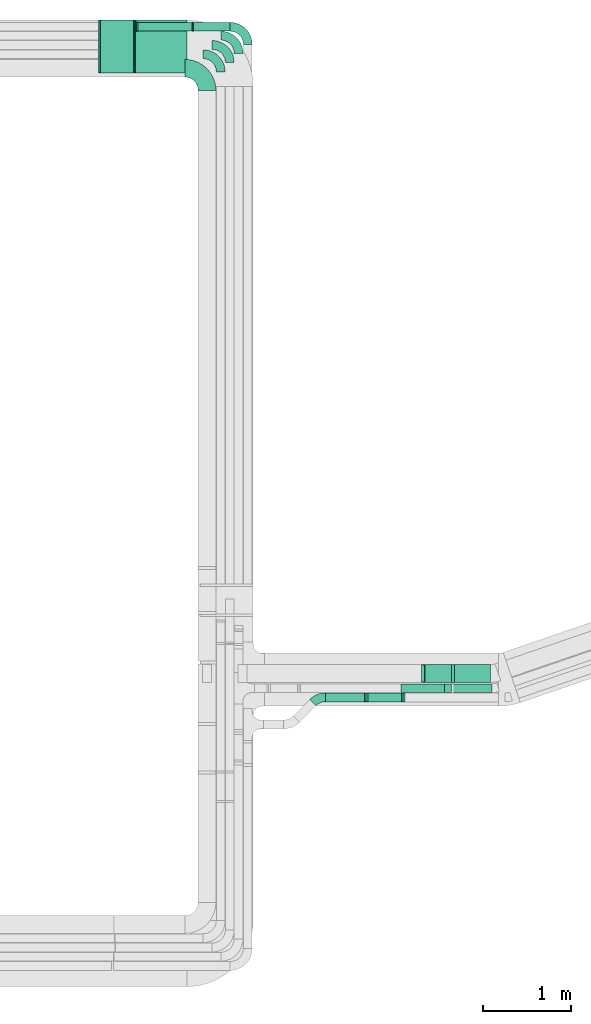
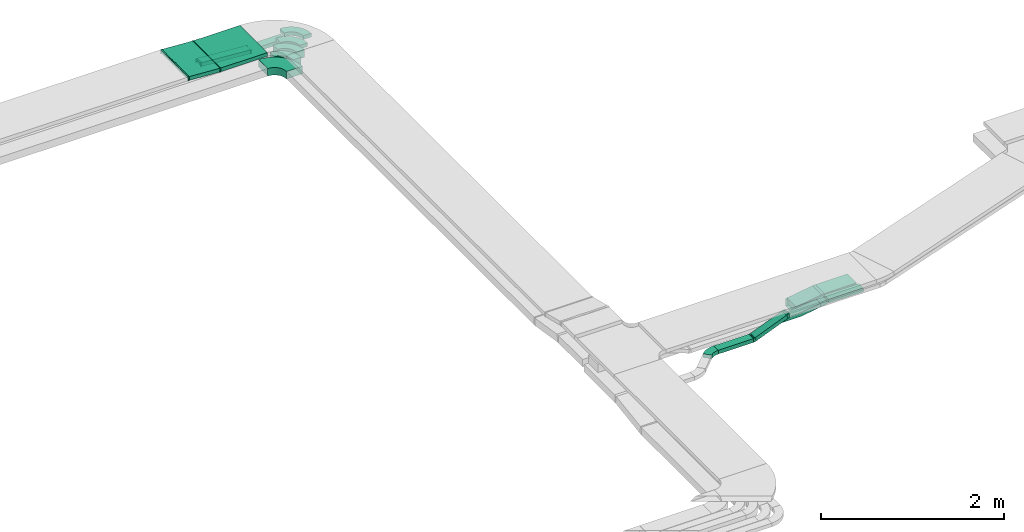
# One storey, part 32 of 38: 15 flow fittings, 10 flow segments.
"""IFC2X3 building model written with IfcOpenShell, lengths in millimetres."""

from ifc_helpers import new_model, entity, si_unit, converted_unit, derived_unit, direction, frame, frame_2d, origin, origin_2d_with_axis, place, context, subcontext, project, spatial, polyline, circle_curve, parameter, trimmed, segment, composite_curve, rectangle, outline, extrude, faceted_brep, source, transform, mapped, material, type_object, type_shapes, element, save


model = new_model("IFC2X3")

# Units and contexts
model_context = context("Model", 3, precision=0.01, world=origin(), true_north=direction((6.12303176911189e-17, 1.0)))
body_context = subcontext(model_context, "Body", "Model", "MODEL_VIEW")
ifc_project = project(units=[si_unit("LENGTHUNIT", "METRE", prefix="MILLI"), si_unit("AREAUNIT", "SQUARE_METRE"), si_unit("VOLUMEUNIT", "CUBIC_METRE"), converted_unit("PLANEANGLEUNIT", "DEGREE", entity("IfcRatioMeasure", 0.0174532925199433), si_unit("PLANEANGLEUNIT", "RADIAN"), dimensions=[0, 0, 0, 0, 0, 0, 0]), si_unit("MASSUNIT", "GRAM", prefix="KILO"), derived_unit("MASSDENSITYUNIT", [(si_unit("MASSUNIT", "GRAM", prefix="KILO"), 1), (si_unit("LENGTHUNIT", "METRE"), -3)]), derived_unit("MOMENTOFINERTIAUNIT", [(si_unit("LENGTHUNIT", "METRE"), 4)]), si_unit("TIMEUNIT", "SECOND"), si_unit("FREQUENCYUNIT", "HERTZ"), si_unit("THERMODYNAMICTEMPERATUREUNIT", "DEGREE_CELSIUS"), derived_unit("THERMALTRANSMITTANCEUNIT", [(si_unit("MASSUNIT", "GRAM", prefix="KILO"), 1), (si_unit("THERMODYNAMICTEMPERATUREUNIT", "KELVIN"), -1), (si_unit("TIMEUNIT", "SECOND"), -3)]), derived_unit("VOLUMETRICFLOWRATEUNIT", [(si_unit("LENGTHUNIT", "METRE"), 3), (si_unit("TIMEUNIT", "SECOND"), -1)]), derived_unit("MASSFLOWRATEUNIT", [(si_unit("MASSUNIT", "GRAM", prefix="KILO"), 1), (si_unit("TIMEUNIT", "SECOND"), -1)]), derived_unit("ROTATIONALFREQUENCYUNIT", [(si_unit("TIMEUNIT", "SECOND"), -1)]), si_unit("ELECTRICCURRENTUNIT", "AMPERE"), si_unit("ELECTRICVOLTAGEUNIT", "VOLT"), si_unit("POWERUNIT", "WATT"), si_unit("FORCEUNIT", "NEWTON", prefix="KILO"), si_unit("ILLUMINANCEUNIT", "LUX"), si_unit("LUMINOUSFLUXUNIT", "LUMEN"), si_unit("LUMINOUSINTENSITYUNIT", "CANDELA"), derived_unit("USERDEFINED", [(si_unit("MASSUNIT", "GRAM", prefix="KILO"), -1), (si_unit("LENGTHUNIT", "METRE"), -2), (si_unit("TIMEUNIT", "SECOND"), 3), (si_unit("LUMINOUSFLUXUNIT", "LUMEN"), 1)]), derived_unit("LINEARVELOCITYUNIT", [(si_unit("LENGTHUNIT", "METRE"), 1), (si_unit("TIMEUNIT", "SECOND"), -1)]), si_unit("PRESSUREUNIT", "PASCAL"), derived_unit("USERDEFINED", [(si_unit("LENGTHUNIT", "METRE"), -2), (si_unit("MASSUNIT", "GRAM", prefix="KILO"), 1), (si_unit("TIMEUNIT", "SECOND"), -2)]), derived_unit("LINEARFORCEUNIT", [(si_unit("MASSUNIT", "GRAM", prefix="KILO"), 1), (si_unit("LENGTHUNIT", "METRE"), 1), (si_unit("TIMEUNIT", "SECOND"), -2), (si_unit("LENGTHUNIT", "METRE"), -1)]), derived_unit("PLANARFORCEUNIT", [(si_unit("MASSUNIT", "GRAM", prefix="KILO"), 1), (si_unit("LENGTHUNIT", "METRE"), 1), (si_unit("TIMEUNIT", "SECOND"), -2), (si_unit("LENGTHUNIT", "METRE"), -2)])], contexts=[model_context])

# Site, building, storey
site_placement = place(None, frame((0.0, -0.00077364408347762, 0.0)))
site = spatial("IfcSite", under=ifc_project, at=site_placement, CompositionType="ELEMENT")
building_placement = place(site_placement, origin())
building = spatial("IfcBuilding", under=site, at=building_placement, CompositionType="ELEMENT")
storey_placement = place(building_placement, frame((0.0, 0.0, 4200.0)))
storey = spatial("IfcBuildingStorey", under=building, at=storey_placement, CompositionType="ELEMENT", Elevation=4200.0)

# Flow segments
cable_carrier_segment_type = type_object("IfcCableCarrierSegmentType", PredefinedType="CABLETRAYSEGMENT")
flow_segment_1_placement = place(storey_placement, frame((60757.9387211652, 15566.1524230659, 2773.40465238002)))
element("IfcFlowSegment", 1, at=flow_segment_1_placement, inside=storey, type_object=cable_carrier_segment_type, context=body_context, shape_type="SweptSolid", body=[
    extrude(rectangle(XDim=585.094690368982, YDim=600.000000000002, at=frame_2d((4.32009983342141e-12, 0.0), x_axis=(1.0, 0.0))), frame((292.547345184487, 300.0, 0.0), z_axis=(0.0, 0.0, 1.0), x_axis=(-1.0, 0.0, 0.0)), (0.0, 0.0, 1.0), 49.9999999999995),
])
flow_segment_2_placement = place(storey_placement, frame((60355.6874307794, 15566.1524230659, 2773.86555364525)))
element("IfcFlowSegment", 2, at=flow_segment_2_placement, inside=storey, type_object=cable_carrier_segment_type, context=body_context, shape_type="SweptSolid", body=[
    extrude(rectangle(XDim=49.9999999999996, YDim=388.064289471167, at=frame_2d((-4.2632564145606e-14, -5.40012479177676e-13), x_axis=(0.0, 1.0))), frame((195.204937503491, 0.0, 36.9237737330479), z_axis=(0.0, 1.0, 0.0), x_axis=(-0.998094861417354, 0.0, 0.0616980357245901)), (0.0, 0.0, 1.0), 600.000000000002),
])
flow_segment_3_placement = place(storey_placement, frame((61417.2080814007, 16039.1762792241, 2500.0)))
element("IfcFlowSegment", 3, at=flow_segment_3_placement, inside=storey, type_object=cable_carrier_segment_type, context=body_context, shape_type="SweptSolid", body=[
    extrude(rectangle(XDim=422.974945905387, YDim=99.9999999999989, at=frame_2d((4.33431068813661e-12, 1.08357767203415e-12), x_axis=(1.0, 0.0))), frame((211.487472952698, 50.0, 0.0), z_axis=(0.0, 0.0, 1.0), x_axis=(-1.0, 0.0, 0.0)), (0.0, 0.0, 1.0), 49.9999999999995),
])
flow_segment_4_placement = place(storey_placement, frame((60781.9444853442, 16039.1762792241, 2500.58430369179)))
element("IfcFlowSegment", 4, at=flow_segment_4_placement, inside=storey, type_object=cable_carrier_segment_type, context=body_context, shape_type="SweptSolid", body=[
    extrude(rectangle(XDim=50.0000000000008, YDim=99.9999999999989, at=frame_2d((0.0, 0.0), x_axis=(0.0, 1.0))), frame((1.83846594978193, 50.0, 70.6053693391281), z_axis=(0.997292368727615, 0.0, -0.0735386379916224), x_axis=(0.0, 1.0, 0.0)), (0.0, 0.0, 1.0), 621.075687126531),
])
flow_segment_5_placement = place(storey_placement, frame((64362.9795024162, 8547.4444137045, 2683.26969738223)))
element("IfcFlowSegment", 5, at=flow_segment_5_placement, inside=storey, type_object=cable_carrier_segment_type, context=body_context, shape_type="SweptSolid", body=[
    extrude(rectangle(XDim=100.000000000001, YDim=438.35134819234, at=frame_2d((4.32009983342141e-12, 0.0), x_axis=(0.0, 1.0))), frame((219.175674182974, 50.0071311780554, 0.0178429227607808), z_axis=(4.88705511740176e-05, -0.000142633733288134, 0.999999988633644), x_axis=(-1.0, 0.0, 4.88705516711381e-05)), (0.0, 0.0, 1.0), 50.0000000000004),
])
flow_segment_6_placement = place(storey_placement, frame((64374.0733170513, 8663.78573364406, 2637.16330868192)))
element("IfcFlowSegment", 6, at=flow_segment_6_placement, inside=storey, type_object=cable_carrier_segment_type, context=body_context, shape_type="SweptSolid", body=[
    extrude(rectangle(XDim=408.398049155987, YDim=200.0, at=origin_2d_with_axis()), frame((204.199024577994, 100.0, 0.0), z_axis=(0.0, 0.0, 1.0), x_axis=(-1.0, 0.0, 0.0)), (0.0, 0.0, 1.0), 99.9999999999989),
])
flow_segment_7_placement = place(storey_placement, frame((64021.5891230622, 8663.78573364406, 2585.29047953296)))
element("IfcFlowSegment", 7, at=flow_segment_7_placement, inside=storey, type_object=cable_carrier_segment_type, context=body_context, shape_type="SweptSolid", body=[
    extrude(rectangle(XDim=99.9999999999992, YDim=200.0, at=origin_2d_with_axis()), frame((7.82172325201104, 100.0, 49.3844170297565), z_axis=(0.987688340595139, 0.0, 0.156434465040222), x_axis=(-0.156434465040222, 0.0, 0.987688340595139)), (0.0, 0.0, 1.0), 322.266039926172),
])
flow_segment_8_placement = place(storey_placement, frame((64258.9077822415, 8547.44797903922, 2669.22010191071)))
element("IfcFlowSegment", 8, at=flow_segment_8_placement, inside=storey, type_object=cable_carrier_segment_type, context=body_context, shape_type="SweptSolid", body=[
    extrude(rectangle(XDim=49.9999999999996, YDim=82.6344223697702, at=frame_2d((0.0, 0.0), x_axis=(0.0, 1.0))), frame((44.7193893792236, 0.0, 31.1556443435394), z_axis=(0.0, 1.0, 0.0), x_axis=(-0.98768834059514, 0.0, -0.156434465040215)), (0.0, 0.0, 1.0), 100.000000000001),
])
flow_segment_9_placement = place(storey_placement, frame((63374.050520388, 8443.54955384748, 2585.00633450531)))
element("IfcFlowSegment", 9, at=flow_segment_9_placement, inside=storey, type_object=cable_carrier_segment_type, context=body_context, shape_type="SweptSolid", body=[
    extrude(rectangle(XDim=49.9999999999932, YDim=99.9999999999989, at=origin_2d_with_axis()), frame((9.36516526349783, 50.0, 23.1795961912024), z_axis=(0.927183847648221, 0.0, 0.374606610539964), x_axis=(-0.374606610539964, 0.0, 0.927183847648221)), (0.0, 0.0, 1.0), 429.833078956127),
])
flow_segment_10_placement = place(storey_placement, frame((62912.7567861421, 8443.54955384748, 2577.30800926447)))
element("IfcFlowSegment", 10, at=flow_segment_10_placement, inside=storey, type_object=cable_carrier_segment_type, context=body_context, shape_type="SweptSolid", body=[
    extrude(rectangle(XDim=440.41961669144, YDim=99.9999999999989, at=origin_2d_with_axis()), frame((220.20980834572, 50.0, 0.0)), (0.0, 0.0, 1.0), 49.9999999999995),
])

# Flow fittings
ifc_material = material()
cable_carrier_fitting_type_1 = type_object("IfcCableCarrierFittingType", Name="470_DKC_S5_Variable Angle Elbow 0-45:-", PredefinedType="NOTDEFINED", material=ifc_material)
shared_shape_1 = source(origin(), body_context, "Body", "SweptSolid", [
    extrude(outline(composite_curve([segment(polyline([(-125.750000000001, -225.25), (-124.749999999999, -225.25)]), True, "CONTINUOUS"), segment(trimmed(circle_curve(frame_2d((-124.75, 124.75), x_axis=(0.0, -1.0)), 350.0), [parameter(0.0)], [parameter(90.0000000000001)], True, "PARAMETER"), True, "CONTINUOUS"), segment(polyline([(225.25, 124.75), (225.25, 125.749999999999)]), True, "CONTINUOUS"), segment(polyline([(225.25, 125.749999999999), (25.25, 125.750000000001)]), True, "CONTINUOUS"), segment(polyline([(25.25, 125.750000000001), (25.25, 124.75)]), True, "CONTINUOUS"), segment(trimmed(circle_curve(frame_2d((-124.75, 124.75), x_axis=(0.0, -1.0)), 150.0), [parameter(0.0)], [parameter(90.0000000000001)], True, "PARAMETER"), False, "CONTINUOUS"), segment(polyline([(-124.749999999999, -25.2500000000003), (-125.750000000001, -25.2500000000003)]), True, "CONTINUOUS"), segment(polyline([(-125.750000000001, -25.2500000000003), (-125.750000000001, -225.25)]), True, "CONTINUOUS")], self_intersect=False)), frame((-125.249999999991, 125.249999999992, -50.0)), (0.0, 0.0, 1.0), 100.0),
])
type_shapes(cable_carrier_fitting_type_1, [shared_shape_1])
flow_fitting_1_placement = place(storey_placement, frame((61571.1830273061, 15619.4933785574, 2596.2), z_axis=(0.00228023645944123, 0.0, 0.999997400257465), x_axis=(0.0, 1.0, 0.0)))
element("IfcFlowFitting", 11, at=flow_fitting_1_placement, inside=storey, type_object=cable_carrier_fitting_type_1, material=ifc_material, Name="470_DKC_S5_Variable Angle Elbow 0-45:-", ObjectType="470_DKC_S5_Variable Angle Elbow 0-45:-", context=body_context, shape_type="MappedRepresentation", body=[
    mapped(shared_shape_1, transform((0.0, 0.0, 0.0), scale=1.0)),
])
cable_carrier_fitting_type_2 = type_object("IfcCableCarrierFittingType", Name="470_DKC_S5_Variable Angle Elbow 0-45:-", PredefinedType="NOTDEFINED", material=ifc_material)
shared_shape_2 = source(origin(), body_context, "Body", "SweptSolid", [
    extrude(outline(composite_curve([segment(polyline([(-100.749999999999, -150.250000000001), (-99.7499999999981, -150.250000000001)]), True, "CONTINUOUS"), segment(trimmed(circle_curve(frame_2d((-99.7500000000006, 99.7499999999987), x_axis=(0.0, -1.0)), 250.0), [parameter(0.0)], [parameter(90.0000000000001)], True, "PARAMETER"), True, "CONTINUOUS"), segment(polyline([(150.249999999999, 99.7500000000013), (150.249999999999, 100.750000000001)]), True, "CONTINUOUS"), segment(polyline([(150.249999999999, 100.750000000001), (50.2499999999992, 100.750000000001)]), True, "CONTINUOUS"), segment(polyline([(50.2499999999992, 100.750000000001), (50.2499999999992, 99.7500000000002)]), True, "CONTINUOUS"), segment(trimmed(circle_curve(frame_2d((-99.7500000000006, 99.7499999999987), x_axis=(0.0, -1.0)), 150.0), [parameter(0.0)], [parameter(90.0000000000001)], True, "PARAMETER"), False, "CONTINUOUS"), segment(polyline([(-99.7499999999989, -50.2500000000011), (-100.75, -50.2500000000011)]), True, "CONTINUOUS"), segment(polyline([(-100.75, -50.2500000000011), (-100.749999999999, -150.250000000001)]), True, "CONTINUOUS")], self_intersect=False)), frame((-100.249999999991, 100.249999999992, -50.0)), (0.0, 0.0, 1.0), 100.0),
])
type_shapes(cable_carrier_fitting_type_2, [shared_shape_2])
for number, where, z_axis, x_axis, name in (
    (12, (61726.2835022257, 15778.4164270114, 2553.41997026524), (0.00225764146350653, 0.0, 0.999997451524264), (0.0, 1.0, 0.0), "470_DKC_S5_Variable Angle Elbow 0-45:-"),
    (13, (61828.6830273062, 15883.4164270114, 2553.43777785335), (0.0, 0.0, 1.0), (0.0, 1.0, 0.0), "470_DKC_S5_Variable Angle Elbow 0-45:-"),
):
    element("IfcFlowFitting", number, at=place(storey_placement, frame(where, z_axis=z_axis, x_axis=x_axis)), inside=storey, type_object=cable_carrier_fitting_type_2, material=ifc_material, Name=name, ObjectType="470_DKC_S5_Variable Angle Elbow 0-45:-", context=body_context, shape_type="MappedRepresentation", body=[
        mapped(shared_shape_2, transform((0.0, 0.0, 0.0), scale=1.0)),
    ])
cable_carrier_fitting_type_3 = type_object("IfcCableCarrierFittingType", Name="470_DKC_S5_Variable Angle Elbow 0-45:-", PredefinedType="NOTDEFINED", material=ifc_material)
shared_shape_3 = source(origin(), body_context, "Body", "SweptSolid", [
    extrude(outline(composite_curve([segment(polyline([(-100.750000000001, -150.25), (-99.7499999999994, -150.25)]), True, "CONTINUOUS"), segment(trimmed(circle_curve(frame_2d((-99.7499999999997, 99.7499999999995), x_axis=(0.0, -1.0)), 250.0), [parameter(0.0)], [parameter(90.0000000000001)], True, "PARAMETER"), True, "CONTINUOUS"), segment(polyline([(150.25, 99.75), (150.25, 100.749999999999)]), True, "CONTINUOUS"), segment(polyline([(150.25, 100.749999999999), (50.25, 100.75)]), True, "CONTINUOUS"), segment(polyline([(50.25, 100.75), (50.25, 99.7499999999998)]), True, "CONTINUOUS"), segment(trimmed(circle_curve(frame_2d((-99.7499999999997, 99.7499999999995), x_axis=(0.0, -1.0)), 150.0), [parameter(0.0)], [parameter(90.0000000000001)], True, "PARAMETER"), False, "CONTINUOUS"), segment(polyline([(-99.7499999999994, -50.2500000000003), (-100.750000000001, -50.2500000000003)]), True, "CONTINUOUS"), segment(polyline([(-100.750000000001, -50.2500000000003), (-100.750000000001, -150.25)]), True, "CONTINUOUS")], self_intersect=False)), frame((-100.249999999991, 100.249999999992, -25.0)), (0.0, 0.0, 1.0), 49.9999999999997),
])
type_shapes(cable_carrier_fitting_type_3, [shared_shape_3])
for number, where, z_axis, x_axis, name in (
    (14, (62032.1830273061, 16089.1762792241, 2602.30800926447), (0.0, 0.0, 1.0), (0.0, 1.0, 0.0), "470_DKC_S5_Variable Angle Elbow 0-45:-"),
    (15, (61928.3352641976, 15988.4164270114, 2571.7), (0.0, 0.0, 1.0), (0.0, 1.0, 0.0), "470_DKC_S5_Variable Angle Elbow 0-45:-"),
):
    element("IfcFlowFitting", number, at=place(storey_placement, frame(where, z_axis=z_axis, x_axis=x_axis)), inside=storey, type_object=cable_carrier_fitting_type_3, material=ifc_material, Name=name, ObjectType="470_DKC_S5_Variable Angle Elbow 0-45:-", context=body_context, shape_type="MappedRepresentation", body=[
        mapped(shared_shape_3, transform((0.0, 0.0, 0.0), scale=1.0)),
    ])
cable_carrier_fitting_type_4 = type_object("IfcCableCarrierFittingType", PredefinedType="NOTDEFINED", material=ifc_material)
shared_shape_4 = source(origin(), body_context, "Body", "Brep", [
    faceted_brep([(-6.69831374394543, -25.0, 300.0), (-6.69831374394527, 25.0, 300.0), (-6.69831374394527, 25.0, 297.460000010164), (-6.69831374394542, -22.46000001016, 297.460000010164), (-6.69831374394542, -22.46000001016, -297.460000010156), (-6.69831374394527, 25.0, -297.460000010156), (-6.69831374394527, 25.0, -300.0), (-6.69831374394543, -25.0, -300.0), (8.22800342110859, -24.5390987347658, 300.0), (8.22800342110859, -24.5390987347659, -300.0), (5.14310163487912, 25.3656443361019, -300.0), (5.14310163487912, 25.3656443361019, -297.460000010156), (8.07129041099499, -22.0039377969064, -297.460000010156), (8.07129041099499, -22.0039377969064, 297.460000010164), (5.14310163487912, 25.3656443361019, 297.460000010164), (5.14310163487912, 25.3656443361019, 300.0), (0.771960792702963, -25.0, 300.0), (-0.771960792702223, 25.0, 300.0), (-0.771960792702223, 25.0, 297.460000010164), (0.69352957647809, -22.46000001016, 297.460000010164), (0.69352957647809, -22.46000001016, -297.460000010156), (-0.771960792702223, 25.0, -297.460000010156), (-0.771960792702223, 25.0, -300.0), (0.771960792702948, -25.0, -300.0)], [[[0, 1, 2, 3, 4, 5, 6, 7]], [[8, 9, 10, 11, 12, 13, 14, 15]], [[1, 0, 16, 8, 15, 17]], [[2, 1, 17, 18]], [[3, 2, 18, 14, 13, 19]], [[4, 3, 19, 20]], [[5, 4, 20, 12, 11, 21]], [[6, 5, 21, 22]], [[7, 6, 22, 10, 9, 23]], [[0, 7, 23, 16]], [[18, 17, 15, 14]], [[20, 19, 13, 12]], [[22, 21, 11, 10]], [[16, 23, 9, 8]]]),
])
type_shapes(cable_carrier_fitting_type_4, [shared_shape_4])
for number, where, z_axis, x_axis in (
    (16, (60751.2404074212, 15866.1524230659, 2798.40465238001), (0.0, 1.0, 0.0), (-1.0, 0.0, 0.0)),
    (17, (60350.5443291445, 15866.1524230659, 2823.17400237659), (0.0, -1.0, 0.0), (-0.998094861417354, 0.0, 0.0616980357245895)),
):
    element("IfcFlowFitting", number, at=place(storey_placement, frame(where, z_axis=z_axis, x_axis=x_axis)), inside=storey, type_object=cable_carrier_fitting_type_4, material=ifc_material, context=body_context, shape_type="MappedRepresentation", body=[
        mapped(shared_shape_4, transform((0.0, 0.0, 0.0), scale=1.0)),
    ])
cable_carrier_fitting_type_5 = type_object("IfcCableCarrierFittingType", PredefinedType="NOTDEFINED", material=ifc_material)
shared_shape_5 = source(origin(), body_context, "Body", "Brep", [
    faceted_brep([(-13.2636792165848, -50.0, 100.0), (-13.2636792165844, 50.0, 100.0), (-13.2636792165844, 50.0, 97.4600000101635), (-13.2636792165847, -47.4600000101599, 97.4600000101635), (-13.2636792165847, -47.4600000101599, -97.4600000101564), (-13.2636792165844, 50.0, -97.4600000101564), (-13.2636792165844, 50.0, -100.0), (-13.2636792165848, -50.0, -100.0), (20.922104567627, -47.3095204670457, 100.0), (20.922104567627, -47.3095204670457, -100.0), (5.27865806360387, 51.4593135924681, -100.0), (5.27865806360387, 51.4593135924681, -97.4600000101564), (20.5247610280142, -44.8007920919689, -97.4600000101564), (20.5247610280142, -44.8007920919689, 97.4600000101635), (5.27865806360387, 51.4593135924681, 97.4600000101635), (5.27865806360387, 51.4593135924681, 100.0), (3.93508534123125, -50.0, 100.0), (-3.9350853412305, 50.0, 100.0), (-3.9350853412305, 50.0, 97.4600000101635), (3.73518300669629, -47.46000001016, 97.4600000101635), (3.73518300669629, -47.46000001016, -97.4600000101564), (-3.9350853412305, 50.0, -97.4600000101564), (-3.9350853412305, 50.0, -100.0), (3.93508534123121, -50.0, -100.0)], [[[0, 1, 2, 3, 4, 5, 6, 7]], [[8, 9, 10, 11, 12, 13, 14, 15]], [[1, 0, 16, 8, 15, 17]], [[2, 1, 17, 18]], [[3, 2, 18, 14, 13, 19]], [[4, 3, 19, 20]], [[5, 4, 20, 12, 11, 21]], [[6, 5, 21, 22]], [[7, 6, 22, 10, 9, 23]], [[0, 7, 23, 16]], [[18, 17, 15, 14]], [[20, 19, 13, 12]], [[22, 21, 11, 10]], [[16, 23, 9, 8]]]),
])
type_shapes(cable_carrier_fitting_type_5, [shared_shape_5])
for number, where, z_axis, x_axis in (
    (18, (64360.8096378347, 8763.78573364406, 2687.16330868192), (0.0, -1.0, 0.0), (-1.0, 0.0, 0.0)),
    (19, (64016.3104649987, 8763.78573364408, 2632.60000000003), (0.0, 1.0, 0.0), (-0.987688340595138, 0.0, -0.156434465040229)),
):
    element("IfcFlowFitting", number, at=place(storey_placement, frame(where, z_axis=z_axis, x_axis=x_axis)), inside=storey, type_object=cable_carrier_fitting_type_5, material=ifc_material, context=body_context, shape_type="MappedRepresentation", body=[
        mapped(shared_shape_5, transform((0.0, 0.0, 0.0), scale=1.0)),
    ])
cable_carrier_fitting_type_6 = type_object("IfcCableCarrierFittingType", Name="470_DKC_S5_CS 90 internal vertical angle:-", PredefinedType="NOTDEFINED", material=ifc_material)
shared_shape_6 = source(origin(), body_context, "Body", "SweptSolid", [
    extrude(outline(composite_curve([segment(polyline([(-248.778844889014, -35.191673560966), (-10.2161368507979, -35.191673560966)]), True, "CONTINUOUS"), segment(trimmed(circle_curve(frame_2d((-10.2161368507982, 129.808326439033), x_axis=(0.0, -1.0)), 164.999999999999), [parameter(0.0)], [parameter(8.99999999999889)], True, "PARAMETER"), True, "CONTINUOUS"), segment(polyline([(15.5955498808369, -33.1602497591641), (251.221155110986, 4.15917985133854)]), True, "CONTINUOUS"), segment(polyline([(251.221155110986, 4.15917985133853), (243.399431858975, 53.5435968810958)]), True, "CONTINUOUS"), segment(polyline([(243.399431858975, 53.5435968810958), (7.7738266288262, 16.2241672705932)]), True, "CONTINUOUS"), segment(trimmed(circle_curve(frame_2d((-10.2161368507982, 129.808326439033), x_axis=(0.0, -1.0)), 114.999999999999), [parameter(0.0)], [parameter(8.99999999999889)], True, "PARAMETER"), False, "CONTINUOUS"), segment(polyline([(-10.2161368507979, 14.8083264390343), (-248.778844889014, 14.8083264390343)]), True, "CONTINUOUS"), segment(polyline([(-248.778844889014, 14.8083264390343), (-248.778844889014, -35.1916735609659)]), True, "CONTINUOUS")], self_intersect=False)), frame((-0.802102104638297, 10.1916735609585, -50.0)), (0.0, 0.0, 1.0), 99.9999999999999),
])
type_shapes(cable_carrier_fitting_type_6, [shared_shape_6])
flow_fitting_2_placement = place(storey_placement, frame((64016.3104524872, 8597.44797903923, 2654.86924849842), z_axis=(0.0, 1.0, 0.0), x_axis=(-0.987688340595139, 0.0, -0.156434465040224)))
element("IfcFlowFitting", 20, at=flow_fitting_2_placement, inside=storey, type_object=cable_carrier_fitting_type_6, material=ifc_material, Name="470_DKC_S5_CS 90 internal vertical angle:-", ObjectType="470_DKC_S5_CS 90 internal vertical angle:-", context=body_context, shape_type="MappedRepresentation", body=[
    mapped(shared_shape_6, transform((0.0, 0.0, 0.0), scale=1.0)),
])
cable_carrier_fitting_type_7 = type_object("IfcCableCarrierFittingType", Name="470_DKC_S5_Variable Angle Elbow 0-45:-", PredefinedType="NOTDEFINED", material=ifc_material)
shared_shape_7 = source(origin(), body_context, "Body", "SweptSolid", [
    extrude(outline(composite_curve([segment(polyline([(-71.6374548139522, -79.4660985766419), (-70.637454813951, -79.4660985766419)]), True, "CONTINUOUS"), segment(trimmed(circle_curve(frame_2d((-70.6374548139513, 170.533901423358), x_axis=(0.0, -1.0)), 250.0), [parameter(0.0)], [parameter(45.0)], True, "PARAMETER"), True, "CONTINUOUS"), segment(polyline([(106.139240482685, -6.24279387327877), (106.846347263872, -5.535687092092)]), True, "CONTINUOUS"), segment(polyline([(106.846347263872, -5.53568709209197), (36.1356691452172, 65.1749910265623)]), True, "CONTINUOUS"), segment(polyline([(36.1356691452171, 65.1749910265622), (35.4285623640307, 64.4678842453758)]), True, "CONTINUOUS"), segment(trimmed(circle_curve(frame_2d((-70.6374548139513, 170.533901423358), x_axis=(0.0, -1.0)), 150.0), [parameter(0.0)], [parameter(45.0)], True, "PARAMETER"), False, "CONTINUOUS"), segment(polyline([(-70.637454813951, 20.5339014233579), (-71.6374548139522, 20.5339014233579)]), True, "CONTINUOUS"), segment(polyline([(-71.6374548139522, 20.5339014233579), (-71.6374548139522, -79.4660985766419)]), True, "CONTINUOUS")], self_intersect=False)), frame((-12.205257660658, 29.4660985766339, -25.0)), (0.0, 0.0, 1.0), 49.9999999999999),
])
type_shapes(cable_carrier_fitting_type_7, [shared_shape_7])
flow_fitting_3_placement = place(storey_placement, frame((62828.9140736675, 8493.54955384747, 2602.30800926447), z_axis=(0.0, 0.0, 1.0), x_axis=(-1.0, 0.0, 0.0)))
element("IfcFlowFitting", 21, at=flow_fitting_3_placement, inside=storey, type_object=cable_carrier_fitting_type_7, material=ifc_material, Name="470_DKC_S5_Variable Angle Elbow 0-45:-", ObjectType="470_DKC_S5_Variable Angle Elbow 0-45:-", context=body_context, shape_type="MappedRepresentation", body=[
    mapped(shared_shape_7, transform((0.0, 0.0, 0.0), scale=1.0)),
])
cable_carrier_fitting_type_8 = type_object("IfcCableCarrierFittingType", PredefinedType="NOTDEFINED", material=ifc_material)
shared_shape_8 = source(origin(), body_context, "Body", "Brep", [
    faceted_brep([(-15.6909175296607, -25.0, 50.0), (-15.6909175296605, 25.0, 50.0), (-15.6909175296605, 25.0, 47.4600000101635), (-15.6909175296607, -22.4600000101599, 47.4600000101635), (-15.6909175296607, -22.4600000101599, -47.4600000101565), (-15.6909175296605, 25.0, -47.4600000101565), (-15.6909175296605, 25.0, -50.0), (-15.6909175296607, -25.0, -50.0), (23.9135305517829, -17.3016747591558, 50.0), (23.9135305517829, -17.3016747591559, -50.0), (5.18320002478138, 29.0575176232539, -50.0), (5.18320002478138, 29.0575176232539, -47.4600000101565), (22.9620297648172, -14.9466277955496, -47.4600000101565), (22.9620297648172, -14.9466277955496, 47.4600000101635), (5.18320002478138, 29.0575176232539, 47.4600000101635), (5.18320002478138, 29.0575176232539, 50.0), (4.85950796802814, -25.0, 50.0), (-4.85950796802734, 25.0, 50.0), (-4.85950796802734, 25.0, 47.4600000101635), (4.36578196045134, -22.46000001016, 47.4600000101635), (4.36578196045134, -22.46000001016, -47.4600000101565), (-4.85950796802734, 25.0, -47.4600000101565), (-4.85950796802734, 25.0, -50.0), (4.85950796802805, -25.0, -50.0)], [[[0, 1, 2, 3, 4, 5, 6, 7]], [[8, 9, 10, 11, 12, 13, 14, 15]], [[1, 0, 16, 8, 15, 17]], [[2, 1, 17, 18]], [[3, 2, 18, 14, 13, 19]], [[4, 3, 19, 20]], [[5, 4, 20, 12, 11, 21]], [[6, 5, 21, 22]], [[7, 6, 22, 10, 9, 23]], [[0, 7, 23, 16]], [[18, 17, 15, 14]], [[20, 19, 13, 12]], [[22, 21, 11, 10]], [[16, 23, 9, 8]]]),
])
type_shapes(cable_carrier_fitting_type_8, [shared_shape_8])
for number, where, z_axis, x_axis in (
    (22, (63796.4983389328, 8493.54955384749, 2775.08216493431), (0.0, -1.0, 0.0), (-1.0, 0.0, 0.0)),
    (23, (63368.8673203632, 8493.54955384748, 2602.30800926446), (0.0, 1.0, 0.0), (-0.927183847648195, 0.0, -0.37460661054003)),
):
    element("IfcFlowFitting", number, at=place(storey_placement, frame(where, z_axis=z_axis, x_axis=x_axis)), inside=storey, type_object=cable_carrier_fitting_type_8, material=ifc_material, context=body_context, shape_type="MappedRepresentation", body=[
        mapped(shared_shape_8, transform((0.0, 0.0, 0.0), scale=1.0)),
    ])
cable_carrier_fitting_type_9 = type_object("IfcCableCarrierFittingType", PredefinedType="NOTDEFINED", material=ifc_material)
shared_shape_9 = source(origin(), body_context, "Body", "Brep", [
    faceted_brep([(-7.0250540946645, -25.0, 50.0), (-7.02505409466434, 25.0, 50.0), (-7.02505409466434, 25.0, 47.4600000101635), (-7.0250540946645, -22.46000001016, 47.4600000101635), (-7.0250540946645, -22.46000001016, -47.4600000101565), (-7.02505409466434, 25.0, -47.4600000101565), (-7.02505409466434, 25.0, -50.0), (-7.0250540946645, -25.0, -50.0), (8.84449878829679, -24.4156963082525, 50.0), (8.84449878829679, -24.4156963082525, -50.0), (5.16756688871987, 25.4489221281286, -50.0), (5.16756688871987, 25.4489221281286, -47.4600000101565), (8.65771064854543, -21.8825737018168, -47.4600000101565), (8.65771064854543, -21.8825737018168, 47.4600000101635), (5.16756688871987, 25.4489221281286, 47.4600000101635), (5.16756688871987, 25.4489221281286, 50.0), (0.920479133938875, -25.0, 50.0), (-0.920479133938133, 25.0, 50.0), (-0.920479133938133, 25.0, 47.4600000101635), (0.826958454304789, -22.46000001016, 47.4600000101635), (0.826958454304789, -22.46000001016, -47.4600000101565), (-0.920479133938133, 25.0, -47.4600000101565), (-0.920479133938133, 25.0, -50.0), (0.920479133938857, -25.0, -50.0)], [[[0, 1, 2, 3, 4, 5, 6, 7]], [[8, 9, 10, 11, 12, 13, 14, 15]], [[1, 0, 16, 8, 15, 17]], [[2, 1, 17, 18]], [[3, 2, 18, 14, 13, 19]], [[4, 3, 19, 20]], [[5, 4, 20, 12, 11, 21]], [[6, 5, 21, 22]], [[7, 6, 22, 10, 9, 23]], [[0, 7, 23, 16]], [[18, 17, 15, 14]], [[20, 19, 13, 12]], [[22, 21, 11, 10]], [[16, 23, 9, 8]]]),
])
type_shapes(cable_carrier_fitting_type_9, [shared_shape_9])
for number, where, z_axis, x_axis in (
    (24, (60776.7769184555, 16089.1762792241, 2571.70628594086), (0.0, 1.0, 0.0), (1.0, 0.0, 0.0)),
    (25, (61410.1830273061, 16089.1762792241, 2525.0), (0.0, 1.0, 0.0), (-1.0, 0.0, 0.0)),
):
    element("IfcFlowFitting", number, at=place(storey_placement, frame(where, z_axis=z_axis, x_axis=x_axis)), inside=storey, type_object=cable_carrier_fitting_type_9, material=ifc_material, context=body_context, shape_type="MappedRepresentation", body=[
        mapped(shared_shape_9, transform((0.0, 0.0, 0.0), scale=1.0)),
    ])

save(model, "model.ifc")
